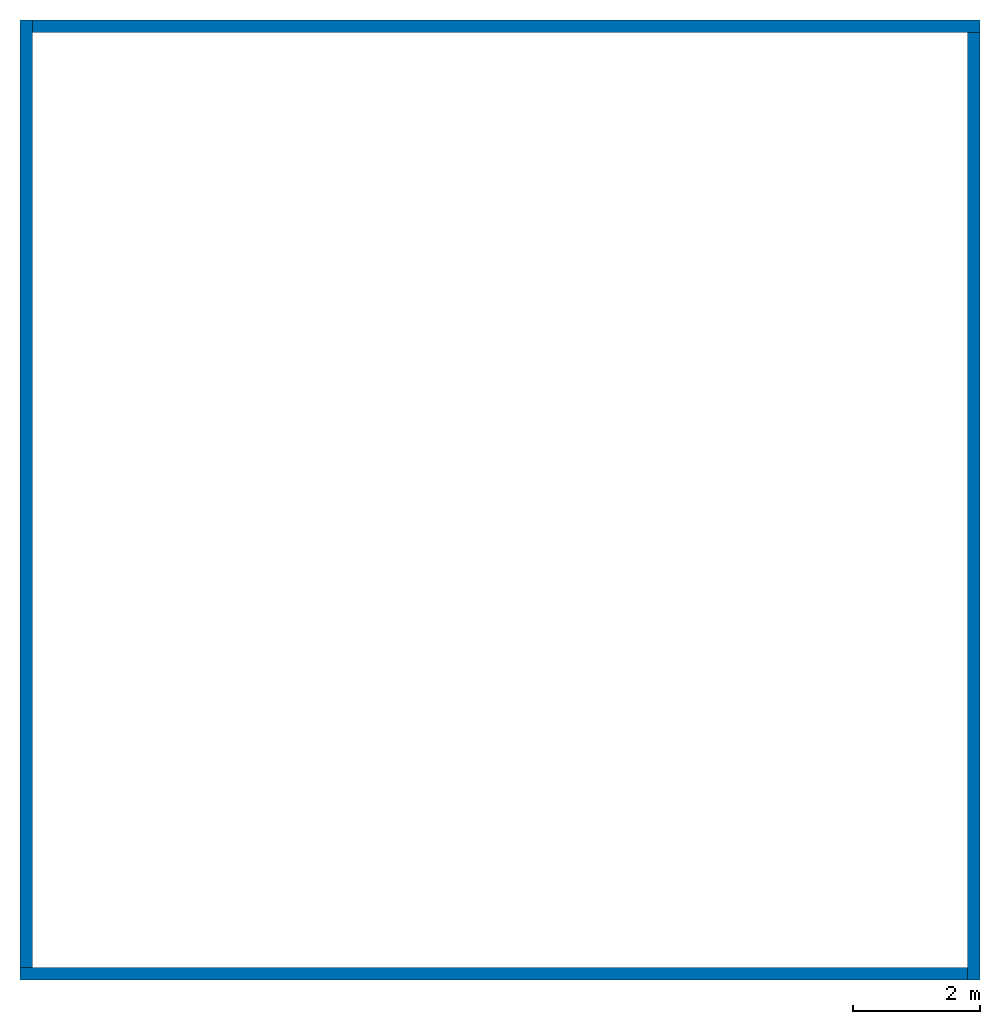
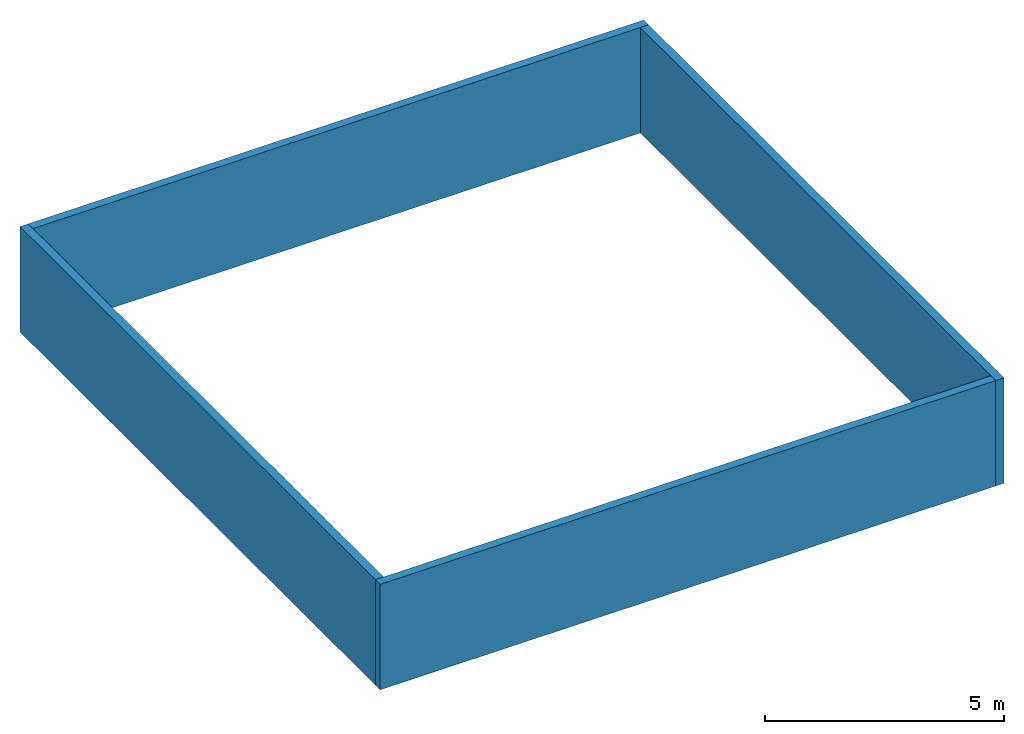
# One storey: 4 walls.
"""IFC2X3 building model written with IfcOpenShell, lengths in millimetres."""

from ifc_helpers import new_model, entity, si_unit, converted_unit, derived_unit, direction, frame, frame_2d, origin, place, context, subcontext, project, spatial, polyline, rectangle, extrude, clip, bounded_halfspace, material, layer, layer_set, layer_usage, type_object, element, save


model = new_model("IFC2X3")

# Units and contexts
model_context = context("Model", 3, precision=0.01, world=origin(), true_north=direction((6.12303176911189e-17, 1.0)))
body_context = subcontext(model_context, "Body", "Model", "MODEL_VIEW")
ifc_project = project(units=[si_unit("LENGTHUNIT", "METRE", prefix="MILLI"), si_unit("AREAUNIT", "SQUARE_METRE"), si_unit("VOLUMEUNIT", "CUBIC_METRE"), converted_unit("PLANEANGLEUNIT", "DEGREE", entity("IfcRatioMeasure", 0.0174532925199433), si_unit("PLANEANGLEUNIT", "RADIAN"), dimensions=[0, 0, 0, 0, 0, 0, 0]), si_unit("MASSUNIT", "GRAM", prefix="KILO"), derived_unit("MASSDENSITYUNIT", [(si_unit("MASSUNIT", "GRAM", prefix="KILO"), 1), (si_unit("LENGTHUNIT", "METRE"), -3)]), si_unit("TIMEUNIT", "SECOND"), si_unit("FREQUENCYUNIT", "HERTZ"), si_unit("THERMODYNAMICTEMPERATUREUNIT", "DEGREE_CELSIUS"), derived_unit("THERMALTRANSMITTANCEUNIT", [(si_unit("MASSUNIT", "GRAM", prefix="KILO"), 1), (si_unit("THERMODYNAMICTEMPERATUREUNIT", "KELVIN"), -1), (si_unit("TIMEUNIT", "SECOND"), -3)]), derived_unit("VOLUMETRICFLOWRATEUNIT", [(si_unit("LENGTHUNIT", "METRE"), 3), (si_unit("TIMEUNIT", "SECOND"), -1)]), si_unit("ELECTRICCURRENTUNIT", "AMPERE"), si_unit("ELECTRICVOLTAGEUNIT", "VOLT"), si_unit("POWERUNIT", "WATT"), si_unit("FORCEUNIT", "NEWTON", prefix="KILO"), si_unit("ILLUMINANCEUNIT", "LUX"), si_unit("LUMINOUSFLUXUNIT", "LUMEN"), si_unit("LUMINOUSINTENSITYUNIT", "CANDELA"), derived_unit("USERDEFINED", [(si_unit("MASSUNIT", "GRAM", prefix="KILO"), -1), (si_unit("LENGTHUNIT", "METRE"), -2), (si_unit("TIMEUNIT", "SECOND"), 3), (si_unit("LUMINOUSFLUXUNIT", "LUMEN"), 1)]), derived_unit("LINEARVELOCITYUNIT", [(si_unit("LENGTHUNIT", "METRE"), 1), (si_unit("TIMEUNIT", "SECOND"), -1)]), si_unit("PRESSUREUNIT", "PASCAL"), derived_unit("USERDEFINED", [(si_unit("LENGTHUNIT", "METRE"), -2), (si_unit("MASSUNIT", "GRAM", prefix="KILO"), 1), (si_unit("TIMEUNIT", "SECOND"), -2)])], contexts=[model_context])

# Site, building, storey
site_placement = place(None, origin())
site = spatial("IfcSite", under=ifc_project, at=site_placement, CompositionType="ELEMENT")
building_placement = place(site_placement, origin())
building = spatial("IfcBuilding", under=site, at=building_placement, CompositionType="ELEMENT")
storey_placement = place(building_placement, origin())
storey = spatial("IfcBuildingStorey", under=building, at=storey_placement, Name="Level 1", CompositionType="ELEMENT", Elevation=0.0)

# Walls
ifc_material = material(Name="Default Wall")
ifc_layer = layer(ifc_material, 200.0)
ifc_layer_set = layer_set([ifc_layer], Name="Basic Wall:Generic - 200mm")
ifc_layer_usage_1 = layer_usage(ifc_layer_set, "AXIS2", "NEGATIVE", 100.0)
wall_type = type_object("IfcWallType", Name="Basic Wall:Generic - 200mm", PredefinedType="STANDARD", material=ifc_layer_set)
wall_1_placement = place(storey_placement, frame((-8084.14374365725, -9182.23321277869, -3000.0)))
element("IfcWallStandardCase", 1, at=wall_1_placement, inside=storey, type_object=wall_type, material=ifc_layer_usage_1, Name="Basic Wall:Generic - 200mm", ObjectType="Basic Wall:Generic - 200mm", context=body_context, shape_type="Clipping", body=[
    clip(extrude(rectangle(XDim=14900.0, YDim=200.0, at=frame_2d((7450.0, 0.0), x_axis=(-1.0, 0.0))), origin(), (0.0, 0.0, 1.0), 2700.0), bounded_halfspace(frame((0.0, -100.0, 2700.0), z_axis=(0.0, 0.0, -1.0), x_axis=(0.0, 1.0, 0.0)), True, frame((0.0, -100.0, 2700.0)), polyline([(0.0, 0.0), (14900.0, 0.0), (14900.0, 200.0), (200.0, 200.0), (0.0, 200.0), (0.0, 0.0)]))),
])
ifc_layer_usage_2 = layer_usage(ifc_layer_set, "AXIS2", "NEGATIVE", 100.0)
wall_2_placement = place(storey_placement, frame((-7984.14374365725, 5817.76678722131, -3000.0), z_axis=(0.0, 0.0, 1.0), x_axis=(0.0, -1.0, 0.0)))
element("IfcWallStandardCase", 2, at=wall_2_placement, inside=storey, type_object=wall_type, material=ifc_layer_usage_2, Name="Basic Wall:Generic - 200mm", ObjectType="Basic Wall:Generic - 200mm", context=body_context, shape_type="Clipping", body=[
    clip(extrude(rectangle(XDim=14900.0, YDim=200.0, at=frame_2d((7450.0, 0.0), x_axis=(-1.0, 0.0))), origin(), (0.0, 0.0, 1.0), 2700.0), bounded_halfspace(frame((0.0, -100.0, 2700.0), z_axis=(0.0, 0.0, -1.0), x_axis=(-1.0, 0.0, 0.0)), True, frame((0.0, -100.0, 2700.0)), polyline([(0.0, 0.0), (14900.0, 0.0), (14900.0, 200.0), (200.0, 200.0), (0.0, 200.0), (0.0, 0.0)]))),
])
ifc_layer_usage_3 = layer_usage(ifc_layer_set, "AXIS2", "NEGATIVE", 100.0)
wall_3_placement = place(storey_placement, frame((7015.85625634275, 5717.76678722131, -3000.0), z_axis=(0.0, 0.0, 1.0), x_axis=(-1.0, 0.0, 0.0)))
element("IfcWallStandardCase", 3, at=wall_3_placement, inside=storey, type_object=wall_type, material=ifc_layer_usage_3, Name="Basic Wall:Generic - 200mm", ObjectType="Basic Wall:Generic - 200mm", context=body_context, shape_type="Clipping", body=[
    clip(extrude(rectangle(XDim=14900.0, YDim=200.0, at=frame_2d((7450.0, 0.0), x_axis=(-1.0, 0.0))), origin(), (0.0, 0.0, 1.0), 2700.0), bounded_halfspace(frame((0.0, -100.0, 2700.0), z_axis=(0.0, 0.0, -1.0), x_axis=(0.0, -1.0, 0.0)), True, frame((0.0, -100.0, 2700.0)), polyline([(0.0, 0.0), (14900.0, 0.0), (14900.0, 200.0), (200.0, 200.0), (0.0, 200.0), (0.0, 0.0)]))),
])
ifc_layer_usage_4 = layer_usage(ifc_layer_set, "AXIS2", "NEGATIVE", 100.0)
wall_4_placement = place(storey_placement, frame((6915.85625634275, -9282.23321277869, -3000.0), z_axis=(0.0, 0.0, 1.0), x_axis=(0.0, 1.0, 0.0)))
element("IfcWallStandardCase", 4, at=wall_4_placement, inside=storey, type_object=wall_type, material=ifc_layer_usage_4, Name="Basic Wall:Generic - 200mm", ObjectType="Basic Wall:Generic - 200mm", context=body_context, shape_type="Clipping", body=[
    clip(extrude(rectangle(XDim=14900.0, YDim=200.0, at=frame_2d((7450.0, 0.0), x_axis=(-1.0, 0.0))), origin(), (0.0, 0.0, 1.0), 2700.0), bounded_halfspace(frame((0.0, -100.0, 2700.0), z_axis=(0.0, 0.0, -1.0), x_axis=(1.0, 0.0, 0.0)), True, frame((0.0, -100.0, 2700.0)), polyline([(0.0, 0.0), (14900.0, 0.0), (14900.0, 200.0), (200.0, 200.0), (0.0, 200.0), (0.0, 0.0)]))),
])

save(model, "model.ifc")
